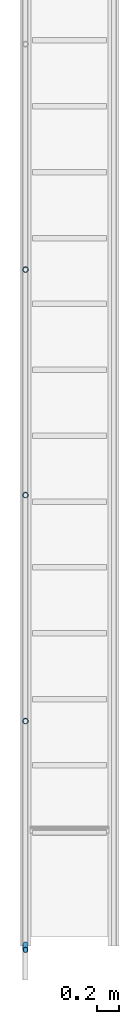
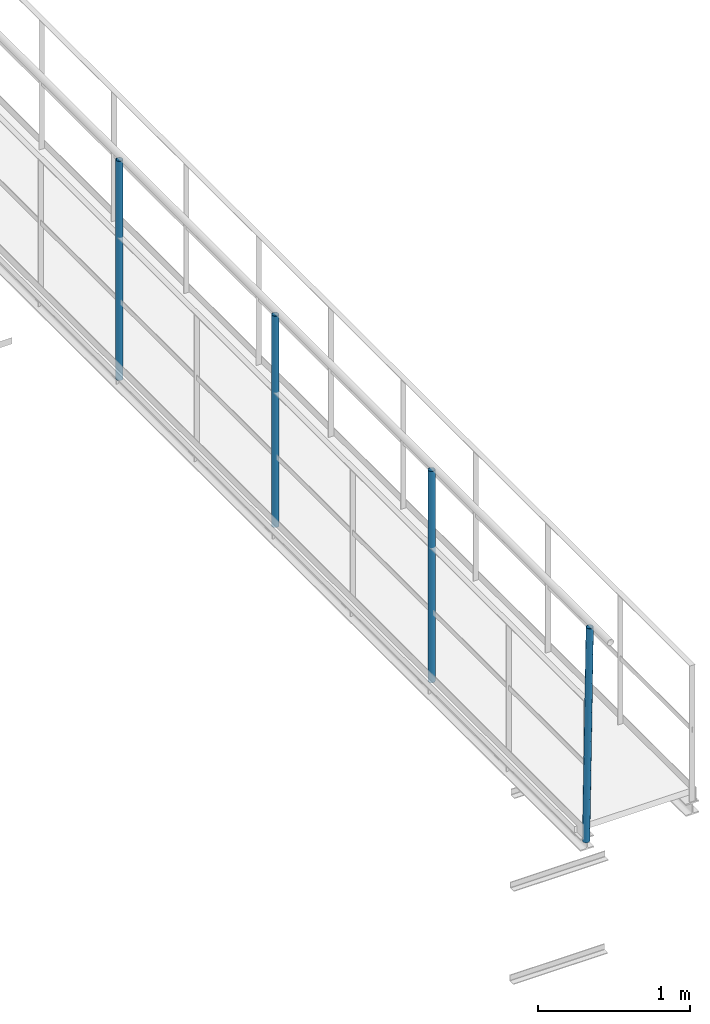
# One storey, part 1 of 6: 4 members.
"""IFC2X3 building model written with IfcOpenShell, lengths in metres."""

import ifcopenshell
import ifcopenshell.guid

model = None  # the IFC model being written
_history = None  # IfcOwnerHistory: only IFC2X3 demands one
_inside = {}  # id of a spatial element -> (the spatial element, [elements in it])
_under = {}  # id of a project, library or spatial element -> (it, [spatial elements below it])
_declared = {}  # id of a project -> (the project, [libraries it declares])
_typed = {}  # id of a type object -> (the type object, [elements of that type])
_made_of = {}  # id of a material, layer set ... -> (it, [elements and type objects made of it])


def new_model(schema):
    """Start an empty IFC model of exactly this schema.

    Asked for "IFC4X3", IfcOpenShell would pick the latest addendum, in which some entities
    have other attributes; the version numbers below select the first issue.
    IFC2X3 requires an IfcOwnerHistory on every rooted entity: one is made here for all.
    """
    global model, _history
    if schema == "IFC4X3":
        model = ifcopenshell.file(schema_version=(4, 3, 0, 0))
    else:
        model = ifcopenshell.file(schema=schema)
    _inside.clear()
    _under.clear()
    _declared.clear()
    _typed.clear()
    _made_of.clear()
    _history = None
    if model.schema == "IFC2X3":
        org = make("IfcOrganization", Name="unknown")
        user = make(
            "IfcPersonAndOrganization",
            ThePerson=make("IfcPerson", FamilyName="unknown"),
            TheOrganization=org,
        )
        app = make(
            "IfcApplication",
            ApplicationDeveloper=org,
            Version="unknown",
            ApplicationFullName="unknown",
            ApplicationIdentifier="unknown",
        )
        _history = make(
            "IfcOwnerHistory",
            OwningUser=user,
            OwningApplication=app,
            ChangeAction="ADDED",
            CreationDate=0,
        )
    return model


def make(cls, **values):
    """One entity of the class cls with the attributes given. An attribute that is None is left unset."""
    return model.create_entity(
        cls, **{name: value for name, value in values.items() if value is not None}
    )


def entity(cls, *values):
    """Any entity or typed value of the class cls, its attributes in the order of the schema. None: left unset."""
    e = model.create_entity(cls)
    for i, value in enumerate(values):
        if value is not None:
            e[i] = value
    return e


def rooted(cls, **values):
    """An entity with a GlobalId (a new one), such as an element, a storey or a relation."""
    return make(cls, GlobalId=ifcopenshell.guid.new(), OwnerHistory=_history, **values)


def si_unit(unit_type, name, prefix=None):
    """IfcSIUnit, for example si_unit("LENGTHUNIT", "METRE", prefix="MILLI")."""
    return make("IfcSIUnit", UnitType=unit_type, Prefix=prefix, Name=name)


def converted_unit(unit_type, name, factor, base, dimensions=None, offset=None):
    """IfcConversionBasedUnit, such as the inch: factor (a typed value) times the base unit."""
    return make(
        "IfcConversionBasedUnit"
        if offset is None
        else "IfcConversionBasedUnitWithOffset",
        ConversionOffset=offset,
        Dimensions=None
        if dimensions is None
        else entity("IfcDimensionalExponents", *dimensions),
        UnitType=unit_type,
        Name=name,
        ConversionFactor=make(
            "IfcMeasureWithUnit", ValueComponent=factor, UnitComponent=base
        ),
    )


def derived_unit(unit_type, elements):
    """IfcDerivedUnit: a product of units, each with its exponent."""
    return make(
        "IfcDerivedUnit",
        Elements=[
            make("IfcDerivedUnitElement", Unit=unit, Exponent=power)
            for unit, power in elements
        ],
        UnitType=unit_type,
    )


def assignment(units):
    """IfcUnitAssignment: the units of a project."""
    return None if units is None else make("IfcUnitAssignment", Units=units)


def point(xyz):
    """IfcCartesianPoint."""
    return None if xyz is None else make("IfcCartesianPoint", Coordinates=xyz)


def direction(xyz):
    """IfcDirection."""
    return None if xyz is None else make("IfcDirection", DirectionRatios=xyz)


def frame(location, z_axis=None, x_axis=None):
    """IfcAxis2Placement3D, a coordinate frame: its origin and axes. An axis left out is left unset."""
    return make(
        "IfcAxis2Placement3D",
        Location=point(location),
        Axis=direction(z_axis),
        RefDirection=direction(x_axis),
    )


def frame_2d(location, x_axis=None):
    """IfcAxis2Placement2D, a coordinate frame in the plane: its origin and x axis."""
    return make(
        "IfcAxis2Placement2D", Location=point(location), RefDirection=direction(x_axis)
    )


def origin():
    """The frame at (0, 0, 0) with its axes left unset."""
    return frame((0.0, 0.0, 0.0))


def place(relative_to, where):
    """IfcLocalPlacement: puts the frame where relative to a parent placement (None: the world)."""
    return make(
        "IfcLocalPlacement", PlacementRelTo=relative_to, RelativePlacement=where
    )


def context(
    kind, dimensions, precision=None, world=None, true_north=None, identifier=None
):
    """IfcGeometricRepresentationContext, for example the 3D "Model" context."""
    return make(
        "IfcGeometricRepresentationContext",
        ContextIdentifier=identifier,
        ContextType=kind,
        CoordinateSpaceDimension=dimensions,
        Precision=precision,
        WorldCoordinateSystem=world,
        TrueNorth=true_north,
    )


def subcontext(parent, identifier, kind, view, scale=None):
    """IfcGeometricRepresentationSubContext, for example "Body" below "Model"."""
    return make(
        "IfcGeometricRepresentationSubContext",
        ContextIdentifier=identifier,
        ContextType=kind,
        ParentContext=parent,
        TargetScale=scale,
        TargetView=view,
    )


def project(units=None, contexts=None):
    """IfcProject with its units and contexts."""
    return rooted(
        "IfcProject",
        Name="project",
        RepresentationContexts=contexts,
        UnitsInContext=assignment(units),
    )


def spatial(cls, under=None, at=None, **own):
    """A site, building, storey or space (cls), placed at a placement, below another one or the project."""
    s = rooted(cls, ObjectPlacement=at, **own)
    if under is not None:
        _under.setdefault(under.id(), (under, []))[1].append(s)
    return s


def profile(cls, at=None, kind="AREA", **sizes):
    """A parametric profile (cls). Its sizes go by their IFC names, for example OverallWidth=200.0."""
    return make(cls, ProfileType=kind, Position=at, **sizes)


def hollow_circle(**sizes):
    """IfcCircleHollowProfileDef."""
    return profile("IfcCircleHollowProfileDef", **sizes)


def extrude(swept, where, along, depth):
    """IfcExtrudedAreaSolid: the profile swept, set in the frame where, extruded along a direction by depth."""
    return make(
        "IfcExtrudedAreaSolid",
        SweptArea=swept,
        Position=where,
        ExtrudedDirection=direction(along),
        Depth=depth,
    )


def shape(context_of_items, identifier, shape_type, items):
    """IfcShapeRepresentation: the items that make up one representation, for example the "Body"."""
    return make(
        "IfcShapeRepresentation",
        ContextOfItems=context_of_items,
        RepresentationIdentifier=identifier,
        RepresentationType=shape_type,
        Items=items,
    )


def source(mapping_origin, context_of_items, identifier, shape_type, items):
    """IfcRepresentationMap: a shape defined once, which mapped items show again and again."""
    return make(
        "IfcRepresentationMap",
        MappingOrigin=mapping_origin,
        MappedRepresentation=shape(context_of_items, identifier, shape_type, items),
    )


def transform(
    local_origin,
    x_axis=None,
    y_axis=None,
    z_axis=None,
    scale=None,
    scale2=None,
    scale3=None,
    uniform=True,
):
    """IfcCartesianTransformationOperator3D, or its non-uniform kind. x_axis, y_axis, z_axis: its Axis1, 2, 3."""
    if uniform:
        return make(
            "IfcCartesianTransformationOperator3D",
            Axis1=direction(x_axis),
            Axis2=direction(y_axis),
            LocalOrigin=point(local_origin),
            Scale=scale,
            Axis3=direction(z_axis),
        )
    return make(
        "IfcCartesianTransformationOperator3DnonUniform",
        Axis1=direction(x_axis),
        Axis2=direction(y_axis),
        LocalOrigin=point(local_origin),
        Scale=scale,
        Axis3=direction(z_axis),
        Scale2=scale2,
        Scale3=scale3,
    )


def mapped(mapping_source, mapping_target):
    """IfcMappedItem: shows the shape of a source again, moved by a transform."""
    return make(
        "IfcMappedItem", MappingSource=mapping_source, MappingTarget=mapping_target
    )


def material(Name=None, Category=None):
    """IfcMaterial."""
    return make("IfcMaterial", Name=Name, Category=Category)


def made_of(thing, what):
    """Note that an element or type object is made of a material, layer set ...; save() writes the relation."""
    if what is not None:
        _made_of.setdefault(what.id(), (what, []))[1].append(thing)
    return thing


def type_object(cls, material=None, **own):
    """A type object (cls), such as IfcWallType, which elements share."""
    return made_of(rooted(cls, **own), material)


def type_shapes(of_type, sources):
    """Give a type object the sources (RepresentationMaps) that its elements show as mapped items."""
    of_type.RepresentationMaps = sources


def element(
    cls,
    number,
    at=None,
    inside=None,
    cuts=None,
    type_object=None,
    material=None,
    context=None,
    identifier="Body",
    shape_type=None,
    held_by="IfcProductDefinitionShape",
    body=None,
    shapes=None,
    **own,
):
    """One element of the class cls, such as IfcWall. Its Tag is "e" and its number.

    at: its placement. inside: the storey or other place that contains it. cuts: it is an
    opening in that element (IfcRelVoidsElement). A single representation is given by context,
    identifier, shape_type and body (its items); several are given by shapes. held_by: the class
    of the entity that holds the representations. save() writes the other relations.
    """
    e = rooted(cls, Tag="e%d" % number, ObjectPlacement=at, **own)
    if body is not None:
        shapes = [shape(context, identifier, shape_type, body)]
    if shapes is not None:
        e.Representation = make(held_by, Representations=shapes)
    if inside is not None:
        _inside.setdefault(inside.id(), (inside, []))[1].append(e)
    if cuts is not None:
        rooted(
            "IfcRelVoidsElement", RelatingBuildingElement=cuts, RelatedOpeningElement=e
        )
    if type_object is not None:
        _typed.setdefault(type_object.id(), (type_object, []))[1].append(e)
    return made_of(e, material)


def aggregate(whole, parts):
    """IfcRelAggregates: a whole, such as a stair, and the parts it consists of."""
    return rooted("IfcRelAggregates", RelatingObject=whole, RelatedObjects=parts)


def save(model, path):
    """Write the relations noted so far, then the file.

    IfcRelAggregates (storeys below a building ...), IfcRelContainedInSpatialStructure (elements
    in a storey), IfcRelDefinesByType, IfcRelAssociatesMaterial and IfcRelDeclares: one each for
    every whole, place, type object, material and project.
    """
    for whole, parts in _under.values():
        aggregate(whole, parts)
    for where, things in _inside.values():
        rooted(
            "IfcRelContainedInSpatialStructure",
            RelatedElements=things,
            RelatingStructure=where,
        )
    for kind, things in _typed.values():
        rooted("IfcRelDefinesByType", RelatedObjects=things, RelatingType=kind)
    for what, things in _made_of.values():
        rooted("IfcRelAssociatesMaterial", RelatedObjects=things, RelatingMaterial=what)
    for by, libraries in _declared.values():
        rooted("IfcRelDeclares", RelatingContext=by, RelatedDefinitions=libraries)
    model.write(path)


model = new_model("IFC2X3")

# Units and contexts
model_context = context("Model", 3, precision=1e-05, world=origin(), true_north=direction((6.123233995736766e-17, 1.0)))
body_context = subcontext(model_context, "Body", "Model", "MODEL_VIEW")
ifc_project = project(units=[si_unit("LENGTHUNIT", "METRE"), converted_unit("PLANEANGLEUNIT", "DEGREE", entity("IfcPlaneAngleMeasure", 0.017453292519943278), si_unit("PLANEANGLEUNIT", "RADIAN"), dimensions=[0, 0, 0, 0, 0, 0, 0]), si_unit("AREAUNIT", "SQUARE_METRE"), derived_unit("THERMALTRANSMITTANCEUNIT", [(si_unit("MASSUNIT", "GRAM", prefix="KILO"), 1), (si_unit("THERMODYNAMICTEMPERATUREUNIT", "KELVIN"), -1), (si_unit("TIMEUNIT", "SECOND"), -3)])], contexts=[model_context])

# Site, building, storey
site_placement = place(None, origin())
site = spatial("IfcSite", under=ifc_project, at=site_placement, CompositionType="ELEMENT")
building_placement = place(site_placement, origin())
building = spatial("IfcBuilding", under=site, at=building_placement, CompositionType="ELEMENT")
storey_placement = place(building_placement, frame((0.0, 0.0, 8.8)))
storey = spatial("IfcBuildingStorey", under=building, at=storey_placement, Name="Piso 2.3", CompositionType="ELEMENT", Elevation=8.8)

# Members
ifc_material = material(Name="Metal - Steel - 345 MPa")
member_type_1 = type_object("IfcMemberType", Name="Circular Hollow Sections:TRON50x2.5", PredefinedType="BRACE", material=ifc_material)
shared_shape_1 = source(origin(), body_context, "Body", "SweptSolid", [
    extrude(hollow_circle(Radius=0.025000000000000813, WallThickness=0.0025000000000008106, at=frame_2d((-6.350472522025309e-19, -4.307027054717513e-17), x_axis=(1.0, 0.0))), frame((-0.9, 0.0, 0.0), z_axis=(1.0, 0.0, 0.0), x_axis=(0.0, 1.0, 0.0)), (0.0, 0.0, 1.0), 1.762),
])
type_shapes(member_type_1, [shared_shape_1])
member_1_placement = place(storey_placement, frame((3.7066971351921274, 1.7952721818317343, 0.9), z_axis=(0.0, -1.0, 0.0), x_axis=(0.0, 0.0, 1.0)))
element("IfcMember", 1, at=member_1_placement, inside=storey, type_object=member_type_1, material=ifc_material, Name="Circular Hollow Sections:TRON50x2.5", ObjectType="Circular Hollow Sections:TRON50x2.5", context=body_context, shape_type="MappedRepresentation", body=[
    mapped(shared_shape_1, transform((0.0, 0.0, 0.0), scale=1.0)),
])
member_type_2 = type_object("IfcMemberType", Name="Circular Hollow Sections:TRON50x2.5", PredefinedType="BRACE", material=ifc_material)
shared_shape_2 = source(origin(), body_context, "Body", "SweptSolid", [
    extrude(hollow_circle(Radius=0.025000000000000813, WallThickness=0.0025000000000008106, at=frame_2d((-6.350472522025309e-19, -4.307027054717513e-17), x_axis=(1.0, 0.0))), frame((-0.8875000000000001, 0.0, 0.0), z_axis=(1.0, 0.0, 0.0), x_axis=(0.0, 1.0, 0.0)), (0.0, 0.0, 1.0), 1.7500000000000002),
])
type_shapes(member_type_2, [shared_shape_2])
member_2_placement = place(storey_placement, frame((3.7066971351921243, -4.376426518782538, 0.8993069786882945), z_axis=(0.0, 0.9996157033272511, 0.027720852468225875), x_axis=(0.0, -0.027720852468225875, 0.9996157033272511)))
element("IfcMember", 2, at=member_2_placement, inside=storey, type_object=member_type_2, material=ifc_material, Name="Circular Hollow Sections:TRON50x2.5", ObjectType="Circular Hollow Sections:TRON50x2.5", context=body_context, shape_type="MappedRepresentation", body=[
    mapped(shared_shape_2, transform((0.0, 0.0, 0.0), scale=1.0)),
])
member_type_3 = type_object("IfcMemberType", Name="Circular Hollow Sections:TRON50x2.5", PredefinedType="BRACE", material=ifc_material)
shared_shape_3 = source(origin(), body_context, "Body", "SweptSolid", [
    extrude(hollow_circle(Radius=0.025000000000000813, WallThickness=0.0025000000000008106, at=frame_2d((-6.350472522025309e-19, -4.307027054717513e-17), x_axis=(1.0, 0.0))), frame((-0.8370000000000001, 0.0, 0.0), z_axis=(1.0, 0.0, 0.0), x_axis=(0.0, 1.0, 0.0)), (0.0, 0.0, 1.0), 1.699),
])
type_shapes(member_type_3, [shared_shape_3])
for number, where, z_axis, x_axis, name in (
    (3, (3.706697135192121, -0.258061151501599, 0.9), (0.0, -1.0, 0.0), (0.0, 0.0, 1.0), "Circular Hollow Sections:TRON50x2.5"),
    (4, (3.7066971351921203, -2.3163944848349343, 0.9), (0.0, -1.0, 0.0), (0.0, 0.0, 1.0), "Circular Hollow Sections:TRON50x2.5"),
):
    element("IfcMember", number, at=place(storey_placement, frame(where, z_axis=z_axis, x_axis=x_axis)), inside=storey, type_object=member_type_3, material=ifc_material, Name=name, ObjectType="Circular Hollow Sections:TRON50x2.5", context=body_context, shape_type="MappedRepresentation", body=[
        mapped(shared_shape_3, transform((0.0, 0.0, 0.0), scale=1.0)),
    ])

save(model, "model.ifc")
